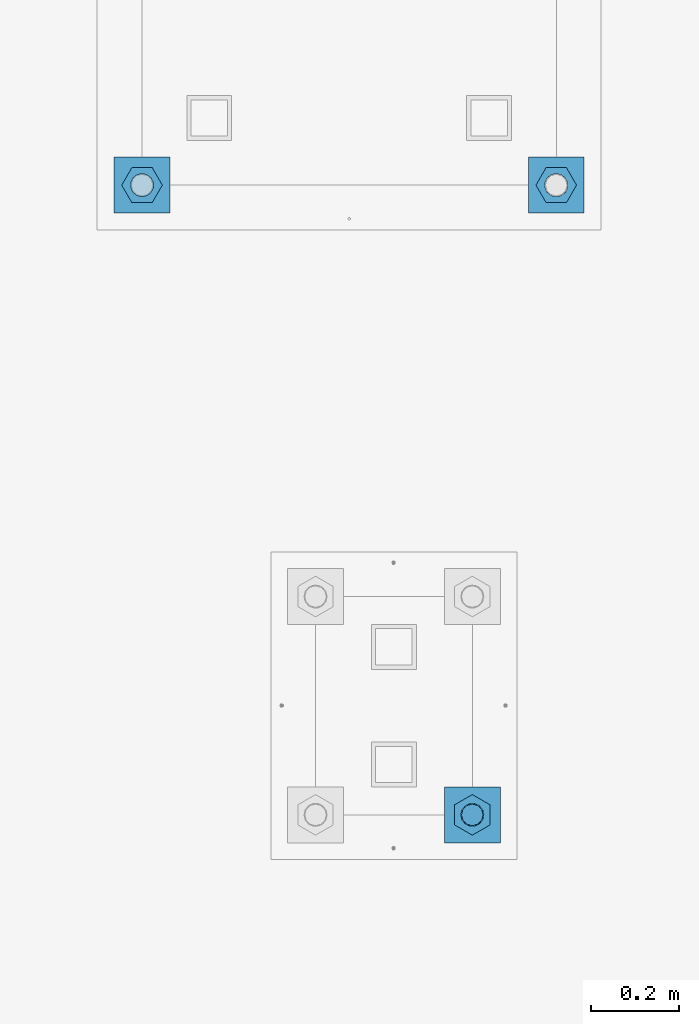
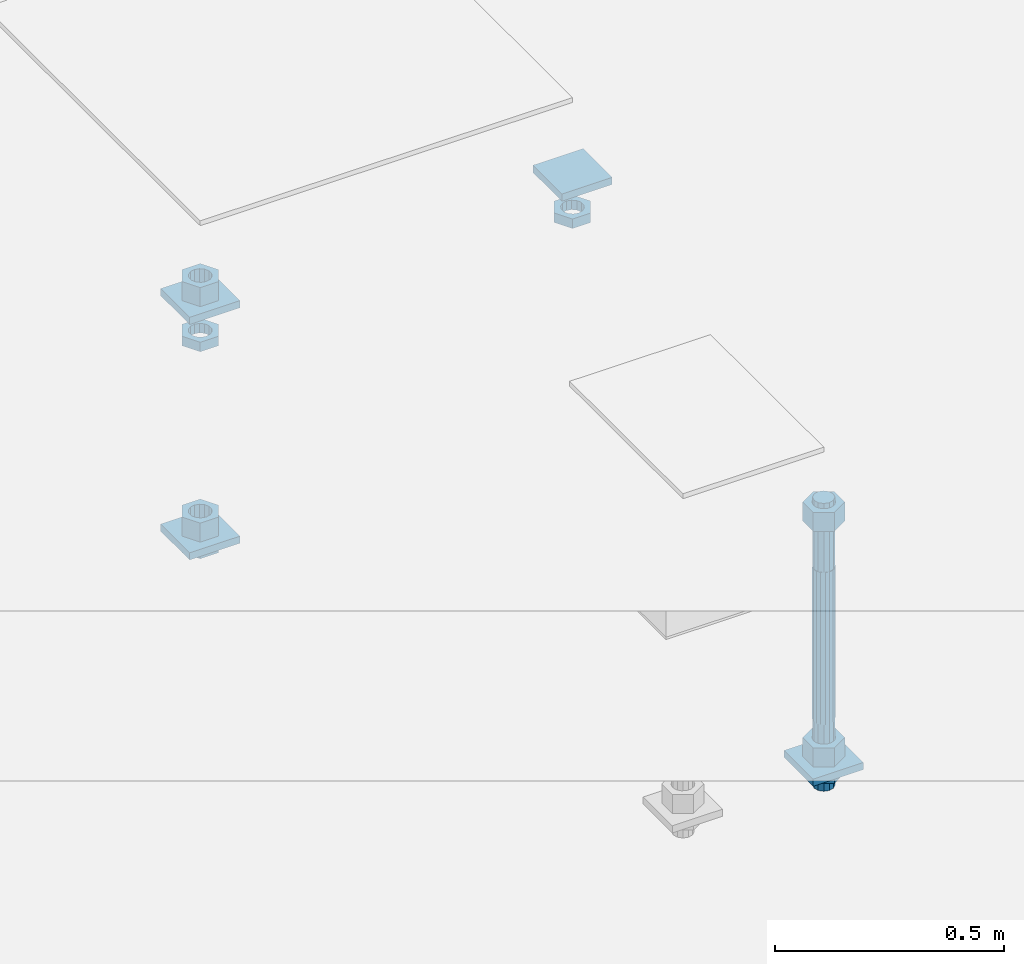
# One storey, part 2563 of 3843: 13 beams, 2 elements without a shape of their own.
"""IFC2X3 building model written with IfcOpenShell, lengths in millimetres."""

from ifc_helpers import new_model, si_unit, frame, origin_with_axes, place, context, subcontext, project, spatial, faceted_brep, material, type_object, element, aggregate, save


model = new_model("IFC2X3")

# Units and contexts
model_context = context("Model", 3, precision=1e-05, world=origin_with_axes())
body_context = subcontext(model_context, "Body", "Model", "MODEL_VIEW")
ifc_project = project(units=[si_unit("LENGTHUNIT", "METRE", prefix="MILLI"), si_unit("AREAUNIT", "SQUARE_METRE"), si_unit("VOLUMEUNIT", "CUBIC_METRE"), si_unit("MASSUNIT", "GRAM", prefix="KILO"), si_unit("TIMEUNIT", "SECOND"), si_unit("PLANEANGLEUNIT", "RADIAN"), si_unit("SOLIDANGLEUNIT", "STERADIAN"), si_unit("THERMODYNAMICTEMPERATUREUNIT", "DEGREE_CELSIUS"), si_unit("LUMINOUSINTENSITYUNIT", "LUMEN")], contexts=[model_context])

# Site, building, storey
site_placement = place(None, origin_with_axes())
site = spatial("IfcSite", under=ifc_project, at=site_placement, CompositionType="ELEMENT")
building_placement = place(site_placement, origin_with_axes())
building = spatial("IfcBuilding", under=site, at=building_placement, Name="Undefined", CompositionType="ELEMENT")
storey_placement = place(building_placement, origin_with_axes())
storey = spatial("IfcBuildingStorey", under=building, at=storey_placement, Name="Undefined", CompositionType="ELEMENT", Elevation=0.0)

# Assembly, beam
assembly_1_placement = place(storey_placement, origin_with_axes())
assembly_1 = element("IfcElementAssembly", 1, at=assembly_1_placement, inside=storey, Name="TEMPLATE", AssemblyPlace="NOTDEFINED", PredefinedType="RIGID_FRAME")
ifc_material_1 = material(Name="STEEL/A572-50")
beam_type_1 = type_object("IfcBeamType", PredefinedType="NOTDEFINED")
beam_1_placement = place(assembly_1_placement, frame((109169.200001526, -247.649999999994, 29244.925), z_axis=(0.0, -1.0, 0.0), x_axis=(1.0, 0.0, 0.0)))
beam_1 = element("IfcBeam", 2, at=beam_1_placement, type_object=beam_type_1, material=ifc_material_1, Name="WASHER_PLATE", context=body_context, shape_type="Brep", body=[
    faceted_brep([(0.0, 9.52500000000146, -63.5), (0.0, 9.52500000000146, 63.5), (127.0, 9.52500000000146, 63.5), (127.0, 9.52500000000146, -63.5), (0.0, -9.52500000000146, 63.5), (127.0, -9.52500000000146, 63.5), (0.0, -9.52500000000146, -63.5), (127.0, -9.52500000000146, -63.5)], [[[0, 1, 2, 3]], [[1, 4, 5, 2]], [[4, 6, 7, 5]], [[6, 0, 3, 7]], [[5, 7, 3, 2]], [[6, 4, 1, 0]]]),
])

# Assembly, beams
assembly_2_placement = place(storey_placement, origin_with_axes())
assembly_2 = element("IfcElementAssembly", 3, at=assembly_2_placement, inside=storey, Name="TEMPLATE", AssemblyPlace="NOTDEFINED", PredefinedType="RIGID_FRAME")
ifc_material_2 = material(Name="STEEL/A36")
beam_2_placement = place(assembly_2_placement, frame((108483.4, 1117.60000152588, 29873.575), z_axis=(1.0, 0.0, 0.0), x_axis=(0.0, 1.0, 0.0)))
beam_2 = element("IfcBeam", 4, at=beam_2_placement, type_object=beam_type_1, material=ifc_material_2, Name="WASHER_PLATE", context=body_context, shape_type="Brep", body=[
    faceted_brep([(0.0, 9.52500000000146, -63.5), (0.0, 9.52500000000146, 63.5), (127.0, 9.52500000000146, 63.5), (127.0, 9.52500000000146, -63.5), (0.0, -9.52500000000146, 63.5), (127.0, -9.52500000000146, 63.5), (0.0, -9.52500000000146, -63.5), (127.0, -9.52500000000146, -63.5)], [[[0, 1, 2, 3]], [[1, 4, 5, 2]], [[4, 6, 7, 5]], [[6, 0, 3, 7]], [[5, 7, 3, 2]], [[6, 4, 1, 0]]]),
])
beam_3_placement = place(assembly_2_placement, frame((109423.2, 1117.60000152588, 29873.575), z_axis=(1.0, 0.0, 0.0), x_axis=(0.0, 1.0, 0.0)))
beam_3 = element("IfcBeam", 5, at=beam_3_placement, type_object=beam_type_1, material=ifc_material_2, Name="WASHER_PLATE", context=body_context, shape_type="Brep", body=[
    faceted_brep([(0.0, 9.52500000000146, -63.5), (0.0, 9.52500000000146, 63.5), (127.0, 9.52500000000146, 63.5), (127.0, 9.52500000000146, -63.5), (0.0, -9.52500000000146, 63.5), (127.0, -9.52500000000146, 63.5), (0.0, -9.52500000000146, -63.5), (127.0, -9.52500000000146, -63.5)], [[[0, 1, 2, 3]], [[1, 4, 5, 2]], [[4, 6, 7, 5]], [[6, 0, 3, 7]], [[5, 7, 3, 2]], [[6, 4, 1, 0]]]),
])
beam_4_placement = place(assembly_2_placement, frame((108483.4, 1117.60000152588, 29244.925), z_axis=(1.0, 0.0, 0.0), x_axis=(0.0, 1.0, 0.0)))
beam_4 = element("IfcBeam", 6, at=beam_4_placement, type_object=beam_type_1, material=ifc_material_2, Name="WASHER_PLATE", context=body_context, shape_type="Brep", body=[
    faceted_brep([(0.0, 9.52500000000146, -63.5), (0.0, 9.52500000000146, 63.5), (127.0, 9.52500000000146, 63.5), (127.0, 9.52500000000146, -63.5), (0.0, -9.52500000000146, 63.5), (127.0, -9.52500000000146, 63.5), (0.0, -9.52500000000146, -63.5), (127.0, -9.52500000000146, -63.5)], [[[0, 1, 2, 3]], [[1, 4, 5, 2]], [[4, 6, 7, 5]], [[6, 0, 3, 7]], [[5, 7, 3, 2]], [[6, 4, 1, 0]]]),
])

# Beam
beam_type_2 = type_object("IfcBeamType", Name="2_HALF_NUT", PredefinedType="NOTDEFINED")
beam_5_placement = place(assembly_1_placement, frame((109232.700001526, -247.649999999994, 29235.4), z_axis=(1.0, 0.0, 0.0), x_axis=(0.0, 0.0, -1.0)))
beam_5 = element("IfcBeam", 7, at=beam_5_placement, type_object=beam_type_2, material=ifc_material_2, Name="NUT", ObjectType="2_HALF_NUT", context=body_context, shape_type="Brep", body=[
    faceted_brep([(0.0, -46.0369987487793, 0.0), (0.0, -23.0184993743896, -39.869213104248), (25.4000000000015, -23.0184993743896, -39.869213104248), (25.4000000000015, -46.0369987487793, 0.0), (0.0, 23.0184993743896, -39.869213104248), (25.4000000000015, 23.0184993743896, -39.869213104248), (0.0, 46.0369987487793, 0.0), (25.4000000000015, 46.0369987487793, 0.0), (0.0, 23.0184993743896, 39.869213104248), (25.4000000000015, 23.0184993743896, 39.869213104248), (0.0, -23.0184993743896, 39.869213104248), (25.4000000000015, -23.0184993743896, 39.869213104248), (0.0, 0.0, 26.1940002441406), (0.0, 11.3650617044477, 23.5999013092805), (25.4000000000015, 11.3650617044477, 23.5999013092805), (25.4000000000015, 0.0, 26.1940002441406), (0.0, 20.4791109456419, 16.3316083006721), (25.4000000000015, 20.4791109456419, 16.3316083006721), (0.0, 25.5370200498292, 5.82867859874386), (25.4000000000015, 25.5370200498292, 5.82867859874386), (0.0, 25.5370200498292, -5.82867859874386), (25.4000000000015, 25.5370200498292, -5.82867859874386), (0.0, 20.4791109456419, -16.3316083006721), (25.4000000000015, 20.4791109456419, -16.3316083006721), (0.0, 11.3650617044477, -23.5999013092805), (25.4000000000015, 11.3650617044477, -23.5999013092805), (0.0, 0.0, -26.1940002441406), (25.4000000000015, 0.0, -26.1940002441406), (0.0, -11.3650617044477, -23.5999013092805), (25.4000000000015, -11.3650617044477, -23.5999013092805), (0.0, -20.4791109456419, -16.3316083006721), (25.4000000000015, -20.4791109456419, -16.3316083006721), (0.0, -25.5370200498292, -5.82867859874386), (25.4000000000015, -25.5370200498292, -5.82867859874386), (0.0, -25.5370200498292, 5.82867859874386), (25.4000000000015, -25.5370200498292, 5.82867859874386), (0.0, -20.4791109456419, 16.3316083006721), (25.4000000000015, -20.4791109456419, 16.3316083006721), (0.0, -11.3650617044477, 23.5999013092805), (25.4000000000015, -11.3650617044477, 23.5999013092805)], [[[0, 1, 2, 3]], [[1, 4, 5, 2]], [[4, 6, 7, 5]], [[6, 8, 9, 7]], [[8, 10, 11, 9]], [[10, 0, 3, 11]], [[12, 13, 14, 15]], [[13, 16, 17, 14]], [[16, 18, 19, 17]], [[18, 20, 21, 19]], [[20, 22, 23, 21]], [[22, 24, 25, 23]], [[24, 26, 27, 25]], [[26, 28, 29, 27]], [[28, 30, 31, 29]], [[30, 32, 33, 31]], [[32, 34, 35, 33]], [[34, 36, 37, 35]], [[36, 38, 39, 37]], [[38, 12, 15, 39]], [[5, 7, 9, 11, 3, 2], [17, 19, 21, 23, 25, 27, 29, 31, 33, 35, 37, 39, 15, 14]], [[10, 8, 6, 4, 1, 0], [38, 36, 34, 32, 30, 28, 26, 24, 22, 20, 18, 16, 13, 12]]]),
])

beam_6_placement = place(assembly_2_placement, frame((108483.4, 1181.10000152588, 29787.85), z_axis=(0.0, -1.0, 0.0), x_axis=(0.0, 0.0, -1.0)))
beam_6 = element("IfcBeam", 8, at=beam_6_placement, type_object=beam_type_2, material=ifc_material_2, Name="NUT", ObjectType="2_HALF_NUT", context=body_context, shape_type="Brep", body=[
    faceted_brep([(0.0, -46.0369987487793, 0.0), (0.0, -23.0184993743896, -39.869213104248), (25.4000000000015, -23.0184993743896, -39.869213104248), (25.4000000000015, -46.0369987487793, 0.0), (0.0, 23.0184993743896, -39.869213104248), (25.4000000000015, 23.0184993743896, -39.869213104248), (0.0, 46.0369987487793, 0.0), (25.4000000000015, 46.0369987487793, 0.0), (0.0, 23.0184993743896, 39.869213104248), (25.4000000000015, 23.0184993743896, 39.869213104248), (0.0, -23.0184993743896, 39.869213104248), (25.4000000000015, -23.0184993743896, 39.869213104248), (0.0, 0.0, 26.1940002441406), (0.0, 11.3650617044477, 23.5999013092805), (25.4000000000015, 11.3650617044477, 23.5999013092805), (25.4000000000015, 0.0, 26.1940002441406), (0.0, 20.4791109456419, 16.3316083006721), (25.4000000000015, 20.4791109456419, 16.3316083006721), (0.0, 25.5370200498292, 5.82867859874386), (25.4000000000015, 25.5370200498292, 5.82867859874386), (0.0, 25.5370200498292, -5.82867859874386), (25.4000000000015, 25.5370200498292, -5.82867859874386), (0.0, 20.4791109456419, -16.3316083006721), (25.4000000000015, 20.4791109456419, -16.3316083006721), (0.0, 11.3650617044477, -23.5999013092805), (25.4000000000015, 11.3650617044477, -23.5999013092805), (0.0, 0.0, -26.1940002441406), (25.4000000000015, 0.0, -26.1940002441406), (0.0, -11.3650617044477, -23.5999013092805), (25.4000000000015, -11.3650617044477, -23.5999013092805), (0.0, -20.4791109456419, -16.3316083006721), (25.4000000000015, -20.4791109456419, -16.3316083006721), (0.0, -25.5370200498292, -5.82867859874386), (25.4000000000015, -25.5370200498292, -5.82867859874386), (0.0, -25.5370200498292, 5.82867859874386), (25.4000000000015, -25.5370200498292, 5.82867859874386), (0.0, -20.4791109456419, 16.3316083006721), (25.4000000000015, -20.4791109456419, 16.3316083006721), (0.0, -11.3650617044477, 23.5999013092805), (25.4000000000015, -11.3650617044477, 23.5999013092805)], [[[0, 1, 2, 3]], [[1, 4, 5, 2]], [[4, 6, 7, 5]], [[6, 8, 9, 7]], [[8, 10, 11, 9]], [[10, 0, 3, 11]], [[12, 13, 14, 15]], [[13, 16, 17, 14]], [[16, 18, 19, 17]], [[18, 20, 21, 19]], [[20, 22, 23, 21]], [[22, 24, 25, 23]], [[24, 26, 27, 25]], [[26, 28, 29, 27]], [[28, 30, 31, 29]], [[30, 32, 33, 31]], [[32, 34, 35, 33]], [[34, 36, 37, 35]], [[36, 38, 39, 37]], [[38, 12, 15, 39]], [[5, 7, 9, 11, 3, 2], [17, 19, 21, 23, 25, 27, 29, 31, 33, 35, 37, 39, 15, 14]], [[10, 8, 6, 4, 1, 0], [38, 36, 34, 32, 30, 28, 26, 24, 22, 20, 18, 16, 13, 12]]]),
])

beam_7_placement = place(assembly_2_placement, frame((109423.2, 1181.10000152588, 29787.85), z_axis=(0.0, 1.0, 0.0), x_axis=(0.0, 0.0, -1.0)))
beam_7 = element("IfcBeam", 9, at=beam_7_placement, type_object=beam_type_2, material=ifc_material_2, Name="NUT", ObjectType="2_HALF_NUT", context=body_context, shape_type="Brep", body=[
    faceted_brep([(0.0, -46.0369987487793, 0.0), (0.0, -23.0184993743896, -39.869213104248), (25.4000000000015, -23.0184993743896, -39.869213104248), (25.4000000000015, -46.0369987487793, 0.0), (0.0, 23.0184993743896, -39.869213104248), (25.4000000000015, 23.0184993743896, -39.869213104248), (0.0, 46.0369987487793, 0.0), (25.4000000000015, 46.0369987487793, 0.0), (0.0, 23.0184993743896, 39.869213104248), (25.4000000000015, 23.0184993743896, 39.869213104248), (0.0, -23.0184993743896, 39.869213104248), (25.4000000000015, -23.0184993743896, 39.869213104248), (0.0, 0.0, 26.1940002441406), (0.0, 11.3650617044477, 23.5999013092805), (25.4000000000015, 11.3650617044477, 23.5999013092805), (25.4000000000015, 0.0, 26.1940002441406), (0.0, 20.4791109456419, 16.3316083006721), (25.4000000000015, 20.4791109456419, 16.3316083006721), (0.0, 25.5370200498292, 5.82867859874386), (25.4000000000015, 25.5370200498292, 5.82867859874386), (0.0, 25.5370200498292, -5.82867859874386), (25.4000000000015, 25.5370200498292, -5.82867859874386), (0.0, 20.4791109456419, -16.3316083006721), (25.4000000000015, 20.4791109456419, -16.3316083006721), (0.0, 11.3650617044477, -23.5999013092805), (25.4000000000015, 11.3650617044477, -23.5999013092805), (0.0, 0.0, -26.1940002441406), (25.4000000000015, 0.0, -26.1940002441406), (0.0, -11.3650617044477, -23.5999013092805), (25.4000000000015, -11.3650617044477, -23.5999013092805), (0.0, -20.4791109456419, -16.3316083006721), (25.4000000000015, -20.4791109456419, -16.3316083006721), (0.0, -25.5370200498292, -5.82867859874386), (25.4000000000015, -25.5370200498292, -5.82867859874386), (0.0, -25.5370200498292, 5.82867859874386), (25.4000000000015, -25.5370200498292, 5.82867859874386), (0.0, -20.4791109456419, 16.3316083006721), (25.4000000000015, -20.4791109456419, 16.3316083006721), (0.0, -11.3650617044477, 23.5999013092805), (25.4000000000015, -11.3650617044477, 23.5999013092805)], [[[0, 1, 2, 3]], [[1, 4, 5, 2]], [[4, 6, 7, 5]], [[6, 8, 9, 7]], [[8, 10, 11, 9]], [[10, 0, 3, 11]], [[12, 13, 14, 15]], [[13, 16, 17, 14]], [[16, 18, 19, 17]], [[18, 20, 21, 19]], [[20, 22, 23, 21]], [[22, 24, 25, 23]], [[24, 26, 27, 25]], [[26, 28, 29, 27]], [[28, 30, 31, 29]], [[30, 32, 33, 31]], [[32, 34, 35, 33]], [[34, 36, 37, 35]], [[36, 38, 39, 37]], [[38, 12, 15, 39]], [[5, 7, 9, 11, 3, 2], [17, 19, 21, 23, 25, 27, 29, 31, 33, 35, 37, 39, 15, 14]], [[10, 8, 6, 4, 1, 0], [38, 36, 34, 32, 30, 28, 26, 24, 22, 20, 18, 16, 13, 12]]]),
])

beam_8_placement = place(assembly_2_placement, frame((108483.4, 1181.10000152588, 29235.4), z_axis=(0.0, -1.0, 0.0), x_axis=(0.0, 0.0, -1.0)))
beam_8 = element("IfcBeam", 10, at=beam_8_placement, type_object=beam_type_2, material=ifc_material_2, Name="NUT", ObjectType="2_HALF_NUT", context=body_context, shape_type="Brep", body=[
    faceted_brep([(0.0, -46.0369987487793, 0.0), (0.0, -23.0184993743896, -39.869213104248), (25.4000000000015, -23.0184993743896, -39.869213104248), (25.4000000000015, -46.0369987487793, 0.0), (0.0, 23.0184993743896, -39.869213104248), (25.4000000000015, 23.0184993743896, -39.869213104248), (0.0, 46.0369987487793, 0.0), (25.4000000000015, 46.0369987487793, 0.0), (0.0, 23.0184993743896, 39.869213104248), (25.4000000000015, 23.0184993743896, 39.869213104248), (0.0, -23.0184993743896, 39.869213104248), (25.4000000000015, -23.0184993743896, 39.869213104248), (0.0, 0.0, 26.1940002441406), (0.0, 11.3650617044477, 23.5999013092805), (25.4000000000015, 11.3650617044477, 23.5999013092805), (25.4000000000015, 0.0, 26.1940002441406), (0.0, 20.4791109456419, 16.3316083006721), (25.4000000000015, 20.4791109456419, 16.3316083006721), (0.0, 25.5370200498292, 5.82867859874386), (25.4000000000015, 25.5370200498292, 5.82867859874386), (0.0, 25.5370200498292, -5.82867859874386), (25.4000000000015, 25.5370200498292, -5.82867859874386), (0.0, 20.4791109456419, -16.3316083006721), (25.4000000000015, 20.4791109456419, -16.3316083006721), (0.0, 11.3650617044477, -23.5999013092805), (25.4000000000015, 11.3650617044477, -23.5999013092805), (0.0, 0.0, -26.1940002441406), (25.4000000000015, 0.0, -26.1940002441406), (0.0, -11.3650617044477, -23.5999013092805), (25.4000000000015, -11.3650617044477, -23.5999013092805), (0.0, -20.4791109456419, -16.3316083006721), (25.4000000000015, -20.4791109456419, -16.3316083006721), (0.0, -25.5370200498292, -5.82867859874386), (25.4000000000015, -25.5370200498292, -5.82867859874386), (0.0, -25.5370200498292, 5.82867859874386), (25.4000000000015, -25.5370200498292, 5.82867859874386), (0.0, -20.4791109456419, 16.3316083006721), (25.4000000000015, -20.4791109456419, 16.3316083006721), (0.0, -11.3650617044477, 23.5999013092805), (25.4000000000015, -11.3650617044477, 23.5999013092805)], [[[0, 1, 2, 3]], [[1, 4, 5, 2]], [[4, 6, 7, 5]], [[6, 8, 9, 7]], [[8, 10, 11, 9]], [[10, 0, 3, 11]], [[12, 13, 14, 15]], [[13, 16, 17, 14]], [[16, 18, 19, 17]], [[18, 20, 21, 19]], [[20, 22, 23, 21]], [[22, 24, 25, 23]], [[24, 26, 27, 25]], [[26, 28, 29, 27]], [[28, 30, 31, 29]], [[30, 32, 33, 31]], [[32, 34, 35, 33]], [[34, 36, 37, 35]], [[36, 38, 39, 37]], [[38, 12, 15, 39]], [[5, 7, 9, 11, 3, 2], [17, 19, 21, 23, 25, 27, 29, 31, 33, 35, 37, 39, 15, 14]], [[10, 8, 6, 4, 1, 0], [38, 36, 34, 32, 30, 28, 26, 24, 22, 20, 18, 16, 13, 12]]]),
])

beam_type_3 = type_object("IfcBeamType", Name="2_HEAVY_HEX_NUT", PredefinedType="NOTDEFINED")
beam_9_placement = place(assembly_1_placement, frame((109232.700001526, -247.649999999994, 29933.9), z_axis=(1.0, 0.0, 0.0), x_axis=(0.0, 0.0, -1.0)))
beam_9 = element("IfcBeam", 11, at=beam_9_placement, type_object=beam_type_3, material=ifc_material_2, Name="NUT", ObjectType="2_HEAVY_HEX_NUT", context=body_context, shape_type="Brep", body=[
    faceted_brep([(0.0, -46.0369987487793, 0.0), (0.0, -23.0184993743896, -39.869213104248), (50.7999999999993, -23.0184993743896, -39.869213104248), (50.7999999999993, -46.0369987487793, 0.0), (0.0, 23.0184993743896, -39.869213104248), (50.7999999999993, 23.0184993743896, -39.869213104248), (0.0, 46.0369987487793, 0.0), (50.7999999999993, 46.0369987487793, 0.0), (0.0, 23.0184993743896, 39.869213104248), (50.7999999999993, 23.0184993743896, 39.869213104248), (0.0, -23.0184993743896, 39.869213104248), (50.7999999999993, -23.0184993743896, 39.869213104248), (0.0, 0.0, 26.1940002441406), (0.0, 11.3650617044477, 23.5999013092805), (50.7999999999993, 11.3650617044477, 23.5999013092805), (50.7999999999993, 0.0, 26.1940002441406), (0.0, 20.4791109456419, 16.3316083006721), (50.7999999999993, 20.4791109456419, 16.3316083006721), (0.0, 25.5370200498292, 5.82867859874386), (50.7999999999993, 25.5370200498292, 5.82867859874386), (0.0, 25.5370200498292, -5.82867859874386), (50.7999999999993, 25.5370200498292, -5.82867859874386), (0.0, 20.4791109456419, -16.3316083006721), (50.7999999999993, 20.4791109456419, -16.3316083006721), (0.0, 11.3650617044477, -23.5999013092805), (50.7999999999993, 11.3650617044477, -23.5999013092805), (0.0, 0.0, -26.1940002441406), (50.7999999999993, 0.0, -26.1940002441406), (0.0, -11.3650617044477, -23.5999013092805), (50.7999999999993, -11.3650617044477, -23.5999013092805), (0.0, -20.4791109456419, -16.3316083006721), (50.7999999999993, -20.4791109456419, -16.3316083006721), (0.0, -25.5370200498292, -5.82867859874386), (50.7999999999993, -25.5370200498292, -5.82867859874386), (0.0, -25.5370200498292, 5.82867859874386), (50.7999999999993, -25.5370200498292, 5.82867859874386), (0.0, -20.4791109456419, 16.3316083006721), (50.7999999999993, -20.4791109456419, 16.3316083006721), (0.0, -11.3650617044477, 23.5999013092805), (50.7999999999993, -11.3650617044477, 23.5999013092805)], [[[0, 1, 2, 3]], [[1, 4, 5, 2]], [[4, 6, 7, 5]], [[6, 8, 9, 7]], [[8, 10, 11, 9]], [[10, 0, 3, 11]], [[12, 13, 14, 15]], [[13, 16, 17, 14]], [[16, 18, 19, 17]], [[18, 20, 21, 19]], [[20, 22, 23, 21]], [[22, 24, 25, 23]], [[24, 26, 27, 25]], [[26, 28, 29, 27]], [[28, 30, 31, 29]], [[30, 32, 33, 31]], [[32, 34, 35, 33]], [[34, 36, 37, 35]], [[36, 38, 39, 37]], [[38, 12, 15, 39]], [[5, 7, 9, 11, 3, 2], [17, 19, 21, 23, 25, 27, 29, 31, 33, 35, 37, 39, 15, 14]], [[10, 8, 6, 4, 1, 0], [38, 36, 34, 32, 30, 28, 26, 24, 22, 20, 18, 16, 13, 12]]]),
])

beam_10_placement = place(assembly_1_placement, frame((109232.700001526, -247.649999999994, 29305.25), z_axis=(1.0, 0.0, 0.0), x_axis=(0.0, 0.0, -1.0)))
beam_10 = element("IfcBeam", 12, at=beam_10_placement, type_object=beam_type_3, material=ifc_material_2, Name="NUT", ObjectType="2_HEAVY_HEX_NUT", context=body_context, shape_type="Brep", body=[
    faceted_brep([(0.0, -46.0369987487793, 0.0), (0.0, -23.0184993743896, -39.869213104248), (50.7999999999993, -23.0184993743896, -39.869213104248), (50.7999999999993, -46.0369987487793, 0.0), (0.0, 23.0184993743896, -39.869213104248), (50.7999999999993, 23.0184993743896, -39.869213104248), (0.0, 46.0369987487793, 0.0), (50.7999999999993, 46.0369987487793, 0.0), (0.0, 23.0184993743896, 39.869213104248), (50.7999999999993, 23.0184993743896, 39.869213104248), (0.0, -23.0184993743896, 39.869213104248), (50.7999999999993, -23.0184993743896, 39.869213104248), (0.0, 0.0, 26.1940002441406), (0.0, 11.3650617044477, 23.5999013092805), (50.7999999999993, 11.3650617044477, 23.5999013092805), (50.7999999999993, 0.0, 26.1940002441406), (0.0, 20.4791109456419, 16.3316083006721), (50.7999999999993, 20.4791109456419, 16.3316083006721), (0.0, 25.5370200498292, 5.82867859874386), (50.7999999999993, 25.5370200498292, 5.82867859874386), (0.0, 25.5370200498292, -5.82867859874386), (50.7999999999993, 25.5370200498292, -5.82867859874386), (0.0, 20.4791109456419, -16.3316083006721), (50.7999999999993, 20.4791109456419, -16.3316083006721), (0.0, 11.3650617044477, -23.5999013092805), (50.7999999999993, 11.3650617044477, -23.5999013092805), (0.0, 0.0, -26.1940002441406), (50.7999999999993, 0.0, -26.1940002441406), (0.0, -11.3650617044477, -23.5999013092805), (50.7999999999993, -11.3650617044477, -23.5999013092805), (0.0, -20.4791109456419, -16.3316083006721), (50.7999999999993, -20.4791109456419, -16.3316083006721), (0.0, -25.5370200498292, -5.82867859874386), (50.7999999999993, -25.5370200498292, -5.82867859874386), (0.0, -25.5370200498292, 5.82867859874386), (50.7999999999993, -25.5370200498292, 5.82867859874386), (0.0, -20.4791109456419, 16.3316083006721), (50.7999999999993, -20.4791109456419, 16.3316083006721), (0.0, -11.3650617044477, 23.5999013092805), (50.7999999999993, -11.3650617044477, 23.5999013092805)], [[[0, 1, 2, 3]], [[1, 4, 5, 2]], [[4, 6, 7, 5]], [[6, 8, 9, 7]], [[8, 10, 11, 9]], [[10, 0, 3, 11]], [[12, 13, 14, 15]], [[13, 16, 17, 14]], [[16, 18, 19, 17]], [[18, 20, 21, 19]], [[20, 22, 23, 21]], [[22, 24, 25, 23]], [[24, 26, 27, 25]], [[26, 28, 29, 27]], [[28, 30, 31, 29]], [[30, 32, 33, 31]], [[32, 34, 35, 33]], [[34, 36, 37, 35]], [[36, 38, 39, 37]], [[38, 12, 15, 39]], [[5, 7, 9, 11, 3, 2], [17, 19, 21, 23, 25, 27, 29, 31, 33, 35, 37, 39, 15, 14]], [[10, 8, 6, 4, 1, 0], [38, 36, 34, 32, 30, 28, 26, 24, 22, 20, 18, 16, 13, 12]]]),
])

beam_11_placement = place(assembly_2_placement, frame((108483.4, 1181.10000152588, 29933.9), z_axis=(0.0, -1.0, 0.0), x_axis=(0.0, 0.0, -1.0)))
beam_11 = element("IfcBeam", 13, at=beam_11_placement, type_object=beam_type_3, material=ifc_material_2, Name="NUT", ObjectType="2_HEAVY_HEX_NUT", context=body_context, shape_type="Brep", body=[
    faceted_brep([(0.0, -46.0369987487793, 0.0), (0.0, -23.0184993743896, -39.869213104248), (50.7999999999993, -23.0184993743896, -39.869213104248), (50.7999999999993, -46.0369987487793, 0.0), (0.0, 23.0184993743896, -39.869213104248), (50.7999999999993, 23.0184993743896, -39.869213104248), (0.0, 46.0369987487793, 0.0), (50.7999999999993, 46.0369987487793, 0.0), (0.0, 23.0184993743896, 39.869213104248), (50.7999999999993, 23.0184993743896, 39.869213104248), (0.0, -23.0184993743896, 39.869213104248), (50.7999999999993, -23.0184993743896, 39.869213104248), (0.0, 0.0, 26.1940002441406), (0.0, 11.3650617044477, 23.5999013092805), (50.7999999999993, 11.3650617044477, 23.5999013092805), (50.7999999999993, 0.0, 26.1940002441406), (0.0, 20.4791109456419, 16.3316083006721), (50.7999999999993, 20.4791109456419, 16.3316083006721), (0.0, 25.5370200498292, 5.82867859874386), (50.7999999999993, 25.5370200498292, 5.82867859874386), (0.0, 25.5370200498292, -5.82867859874386), (50.7999999999993, 25.5370200498292, -5.82867859874386), (0.0, 20.4791109456419, -16.3316083006721), (50.7999999999993, 20.4791109456419, -16.3316083006721), (0.0, 11.3650617044477, -23.5999013092805), (50.7999999999993, 11.3650617044477, -23.5999013092805), (0.0, 0.0, -26.1940002441406), (50.7999999999993, 0.0, -26.1940002441406), (0.0, -11.3650617044477, -23.5999013092805), (50.7999999999993, -11.3650617044477, -23.5999013092805), (0.0, -20.4791109456419, -16.3316083006721), (50.7999999999993, -20.4791109456419, -16.3316083006721), (0.0, -25.5370200498292, -5.82867859874386), (50.7999999999993, -25.5370200498292, -5.82867859874386), (0.0, -25.5370200498292, 5.82867859874386), (50.7999999999993, -25.5370200498292, 5.82867859874386), (0.0, -20.4791109456419, 16.3316083006721), (50.7999999999993, -20.4791109456419, 16.3316083006721), (0.0, -11.3650617044477, 23.5999013092805), (50.7999999999993, -11.3650617044477, 23.5999013092805)], [[[0, 1, 2, 3]], [[1, 4, 5, 2]], [[4, 6, 7, 5]], [[6, 8, 9, 7]], [[8, 10, 11, 9]], [[10, 0, 3, 11]], [[12, 13, 14, 15]], [[13, 16, 17, 14]], [[16, 18, 19, 17]], [[18, 20, 21, 19]], [[20, 22, 23, 21]], [[22, 24, 25, 23]], [[24, 26, 27, 25]], [[26, 28, 29, 27]], [[28, 30, 31, 29]], [[30, 32, 33, 31]], [[32, 34, 35, 33]], [[34, 36, 37, 35]], [[36, 38, 39, 37]], [[38, 12, 15, 39]], [[5, 7, 9, 11, 3, 2], [17, 19, 21, 23, 25, 27, 29, 31, 33, 35, 37, 39, 15, 14]], [[10, 8, 6, 4, 1, 0], [38, 36, 34, 32, 30, 28, 26, 24, 22, 20, 18, 16, 13, 12]]]),
])

beam_12_placement = place(assembly_2_placement, frame((108483.4, 1181.10000152588, 29305.25), z_axis=(0.0, -1.0, 0.0), x_axis=(0.0, 0.0, -1.0)))
beam_12 = element("IfcBeam", 14, at=beam_12_placement, type_object=beam_type_3, material=ifc_material_2, Name="NUT", ObjectType="2_HEAVY_HEX_NUT", context=body_context, shape_type="Brep", body=[
    faceted_brep([(0.0, -46.0369987487793, 0.0), (0.0, -23.0184993743896, -39.869213104248), (50.7999999999993, -23.0184993743896, -39.869213104248), (50.7999999999993, -46.0369987487793, 0.0), (0.0, 23.0184993743896, -39.869213104248), (50.7999999999993, 23.0184993743896, -39.869213104248), (0.0, 46.0369987487793, 0.0), (50.7999999999993, 46.0369987487793, 0.0), (0.0, 23.0184993743896, 39.869213104248), (50.7999999999993, 23.0184993743896, 39.869213104248), (0.0, -23.0184993743896, 39.869213104248), (50.7999999999993, -23.0184993743896, 39.869213104248), (0.0, 0.0, 26.1940002441406), (0.0, 11.3650617044477, 23.5999013092805), (50.7999999999993, 11.3650617044477, 23.5999013092805), (50.7999999999993, 0.0, 26.1940002441406), (0.0, 20.4791109456419, 16.3316083006721), (50.7999999999993, 20.4791109456419, 16.3316083006721), (0.0, 25.5370200498292, 5.82867859874386), (50.7999999999993, 25.5370200498292, 5.82867859874386), (0.0, 25.5370200498292, -5.82867859874386), (50.7999999999993, 25.5370200498292, -5.82867859874386), (0.0, 20.4791109456419, -16.3316083006721), (50.7999999999993, 20.4791109456419, -16.3316083006721), (0.0, 11.3650617044477, -23.5999013092805), (50.7999999999993, 11.3650617044477, -23.5999013092805), (0.0, 0.0, -26.1940002441406), (50.7999999999993, 0.0, -26.1940002441406), (0.0, -11.3650617044477, -23.5999013092805), (50.7999999999993, -11.3650617044477, -23.5999013092805), (0.0, -20.4791109456419, -16.3316083006721), (50.7999999999993, -20.4791109456419, -16.3316083006721), (0.0, -25.5370200498292, -5.82867859874386), (50.7999999999993, -25.5370200498292, -5.82867859874386), (0.0, -25.5370200498292, 5.82867859874386), (50.7999999999993, -25.5370200498292, 5.82867859874386), (0.0, -20.4791109456419, 16.3316083006721), (50.7999999999993, -20.4791109456419, 16.3316083006721), (0.0, -11.3650617044477, 23.5999013092805), (50.7999999999993, -11.3650617044477, 23.5999013092805)], [[[0, 1, 2, 3]], [[1, 4, 5, 2]], [[4, 6, 7, 5]], [[6, 8, 9, 7]], [[8, 10, 11, 9]], [[10, 0, 3, 11]], [[12, 13, 14, 15]], [[13, 16, 17, 14]], [[16, 18, 19, 17]], [[18, 20, 21, 19]], [[20, 22, 23, 21]], [[22, 24, 25, 23]], [[24, 26, 27, 25]], [[26, 28, 29, 27]], [[28, 30, 31, 29]], [[30, 32, 33, 31]], [[32, 34, 35, 33]], [[34, 36, 37, 35]], [[36, 38, 39, 37]], [[38, 12, 15, 39]], [[5, 7, 9, 11, 3, 2], [17, 19, 21, 23, 25, 27, 29, 31, 33, 35, 37, 39, 15, 14]], [[10, 8, 6, 4, 1, 0], [38, 36, 34, 32, 30, 28, 26, 24, 22, 20, 18, 16, 13, 12]]]),
])

aggregate(assembly_2, [beam_6, beam_7, beam_2, beam_3, beam_11, beam_12, beam_8, beam_4])

ifc_material_3 = material()
beam_type_4 = type_object("IfcBeamType", PredefinedType="NOTDEFINED")
beam_13_placement = place(assembly_1_placement, frame((109232.700001526, -247.649999999994, 29762.45), z_axis=(1.0, 0.0, 0.0), x_axis=(0.0, 0.0, -1.0)))
beam_13 = element("IfcBeam", 15, at=beam_13_placement, type_object=beam_type_4, material=ifc_material_3, Name="ANCHOR_ROD", context=body_context, shape_type="Brep", body=[
    faceted_brep([(-184.150000000001, -21.217622392709, 12.25), (-184.150000000001, -12.2499999999854, 21.2176223927163), (-184.150000000001, 1.45519152283669e-11, 24.5), (-184.150000000001, 12.2500000000146, 21.2176223927163), (-184.150000000001, 21.2176223927381, 12.25), (-184.150000000001, 24.5000000000146, 0.0), (-184.150000000001, 21.2176223927381, -12.25), (-184.150000000001, 12.2500000000146, -21.2176223927163), (-184.150000000001, 1.45519152283669e-11, -24.5), (-184.150000000001, -12.2499999999854, -21.2176223927163), (-184.150000000001, -21.217622392709, -12.25), (-184.150000000001, -24.4999999999854, 0.0), (0.0, 24.5000000000146, 0.0), (0.0, 21.2176223927381, -12.25), (0.0, 12.2500000000146, -21.2176223927163), (0.0, 1.45519152283669e-11, -24.5), (0.0, -12.2499999999854, -21.2176223927163), (0.0, -21.217622392709, -12.25), (0.0, -24.4999999999854, 0.0), (0.0, -21.217622392709, 12.25), (0.0, -12.2499999999854, 21.2176223927163), (0.0, 1.45519152283669e-11, 24.5), (0.0, 12.2500000000146, 21.2176223927163), (0.0, 21.2176223927381, 12.25), (0.0, -23.4665401257807, 9.72015918207035), (0.0, -17.9605122421344, 17.9605122421417), (0.0, -9.72015918207762, 23.466540125788), (0.0, 0.0, 25.4000000000015), (0.0, 9.72015918207762, 23.466540125788), (0.0, 17.9605122421344, 17.9605122421417), (0.0, 23.4665401257807, 9.72015918207035), (0.0, 25.3999996185303, 0.0), (0.0, 23.4665401257807, -9.72015918207035), (0.0, 17.9605122421344, -17.9605122421417), (0.0, 9.72015918207762, -23.466540125788), (0.0, 0.0, -25.4000000000015), (0.0, -9.72015918207762, -23.466540125788), (0.0, -17.9605122421344, -17.9605122421417), (0.0, -23.4665401257807, -9.72015918207035), (0.0, -25.3999996185303, 0.0), (406.399999999998, -25.3999999999942, 0.0), (406.399999999998, -23.4665401257807, 9.72015918207035), (406.399999999998, -17.9605122421344, 17.9605122421417), (406.399999999998, -9.72015918207762, 23.466540125788), (406.399999999998, 0.0, 25.4000000000015), (406.399999999998, 9.72015918207762, 23.466540125788), (406.399999999998, 17.9605122421344, 17.9605122421417), (406.399999999998, 23.4665401257807, 9.72015918207035), (406.399999999998, 25.3999999999942, 0.0), (406.399999999998, 23.4665401257807, -9.72015918207035), (406.399999999998, 17.9605122421344, -17.9605122421417), (406.399999999998, 9.72015918207762, -23.466540125788), (406.399999999998, 0.0, -25.4000000000015), (406.399999999998, -9.72015918207762, -23.466540125788), (406.399999999998, -17.9605122421344, -17.9605122421417), (406.399999999998, -23.4665401257807, -9.72015918207035), (406.399999999998, -12.2499999999854, 21.2176223927163), (406.399999999998, 1.45519152283669e-11, 24.5), (406.399999999998, 12.2500000000146, 21.2176223927163), (406.399999999998, 21.2176223927381, 12.25), (406.399999999998, 24.5000000000146, 0.0), (406.399999999998, 21.2176223927381, -12.25), (406.399999999998, 12.2500000000146, -21.2176223927163), (406.399999999998, 1.45519152283669e-11, -24.5), (406.399999999998, -12.2499999999854, -21.2176223927163), (406.399999999998, -21.217622392709, -12.25), (406.399999999998, -24.4999999999854, 0.0), (406.399999999998, -21.217622392709, 12.25), (584.200000000001, -12.2499999999854, -21.2176223927163), (584.200000000001, 1.45519152283669e-11, -24.5), (584.200000000001, 12.2500000000146, -21.2176223927163), (584.200000000001, 21.2176223927381, -12.25), (584.200000000001, 24.5000000000146, 0.0), (584.200000000001, 21.2176223927381, 12.25), (584.200000000001, 12.2500000000146, 21.2176223927163), (584.200000000001, 1.45519152283669e-11, 24.5), (584.200000000001, -12.2499999999854, 21.2176223927163), (584.200000000001, -21.217622392709, 12.25), (584.200000000001, -24.4999999999854, 0.0), (584.200000000001, -21.217622392709, -12.25)], [[[0, 1, 2, 3, 4, 5, 6, 7, 8, 9, 10, 11]], [[6, 5, 12, 13]], [[7, 6, 13, 14]], [[8, 7, 14, 15]], [[9, 8, 15, 16]], [[10, 9, 16, 17]], [[11, 10, 17, 18]], [[0, 11, 18, 19]], [[1, 0, 19, 20]], [[2, 1, 20, 21]], [[3, 2, 21, 22]], [[4, 3, 22, 23]], [[5, 4, 23, 12]], [[24, 25, 26, 27, 28, 29, 30, 31, 32, 33, 34, 35, 36, 37, 38, 39], [22, 21, 20, 19, 18, 17, 16, 15, 14, 13, 12, 23]], [[24, 39, 40, 41]], [[25, 24, 41, 42]], [[26, 25, 42, 43]], [[27, 26, 43, 44]], [[28, 27, 44, 45]], [[29, 28, 45, 46]], [[30, 29, 46, 47]], [[31, 30, 47, 48]], [[32, 31, 48, 49]], [[33, 32, 49, 50]], [[34, 33, 50, 51]], [[35, 34, 51, 52]], [[36, 35, 52, 53]], [[37, 36, 53, 54]], [[38, 37, 54, 55]], [[39, 38, 55, 40]], [[54, 53, 52, 51, 50, 49, 48, 47, 46, 45, 44, 43, 42, 41, 40, 55], [56, 57, 58, 59, 60, 61, 62, 63, 64, 65, 66, 67]], [[68, 69, 70, 71, 72, 73, 74, 75, 76, 77, 78, 79]], [[76, 75, 57, 56]], [[77, 76, 56, 67]], [[78, 77, 67, 66]], [[79, 78, 66, 65]], [[68, 79, 65, 64]], [[69, 68, 64, 63]], [[70, 69, 63, 62]], [[71, 70, 62, 61]], [[72, 71, 61, 60]], [[73, 72, 60, 59]], [[74, 73, 59, 58]], [[75, 74, 58, 57]]]),
])

aggregate(assembly_1, [beam_9, beam_10, beam_5, beam_1, beam_13])

save(model, "model.ifc")
